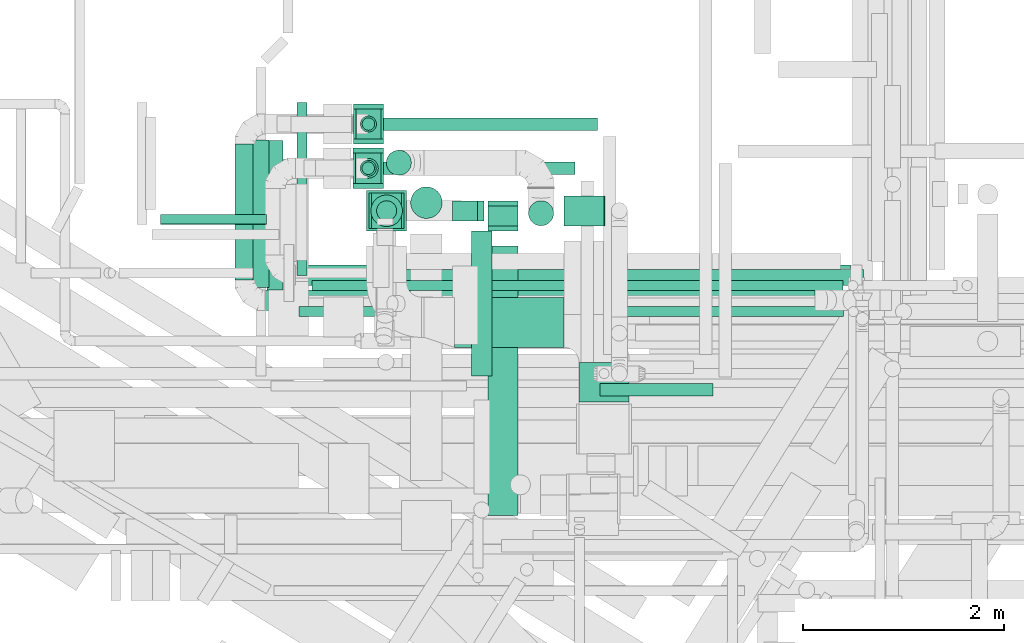
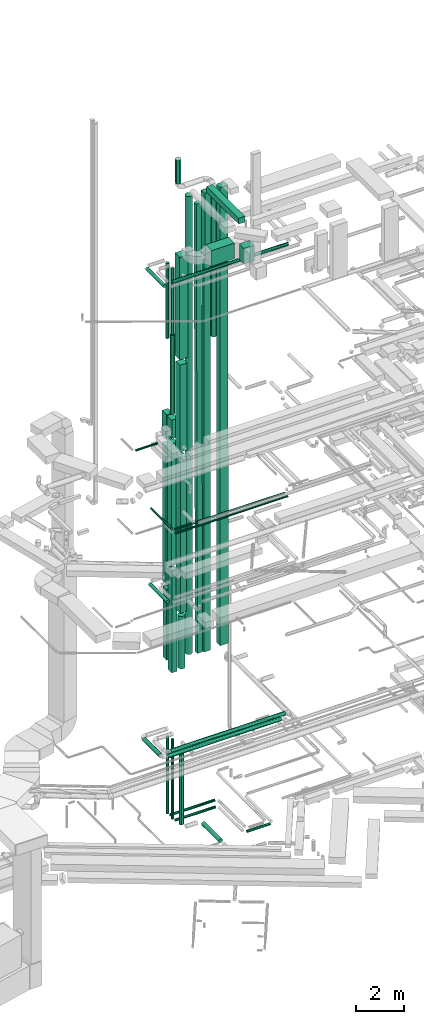
# One storey, part 26 of 337: 40 flow segments.
"""IFC2X3 building model written with IfcOpenShell, lengths in millimetres."""

import ifcopenshell
import ifcopenshell.guid

model = None  # the IFC model being written
_history = None  # IfcOwnerHistory: only IFC2X3 demands one
_inside = {}  # id of a spatial element -> (the spatial element, [elements in it])
_under = {}  # id of a project, library or spatial element -> (it, [spatial elements below it])
_declared = {}  # id of a project -> (the project, [libraries it declares])
_typed = {}  # id of a type object -> (the type object, [elements of that type])
_made_of = {}  # id of a material, layer set ... -> (it, [elements and type objects made of it])


def new_model(schema):
    """Start an empty IFC model of exactly this schema.

    Asked for "IFC4X3", IfcOpenShell would pick the latest addendum, in which some entities
    have other attributes; the version numbers below select the first issue.
    IFC2X3 requires an IfcOwnerHistory on every rooted entity: one is made here for all.
    """
    global model, _history
    if schema == "IFC4X3":
        model = ifcopenshell.file(schema_version=(4, 3, 0, 0))
    else:
        model = ifcopenshell.file(schema=schema)
    _inside.clear()
    _under.clear()
    _declared.clear()
    _typed.clear()
    _made_of.clear()
    _history = None
    if model.schema == "IFC2X3":
        org = make("IfcOrganization", Name="unknown")
        user = make(
            "IfcPersonAndOrganization",
            ThePerson=make("IfcPerson", FamilyName="unknown"),
            TheOrganization=org,
        )
        app = make(
            "IfcApplication",
            ApplicationDeveloper=org,
            Version="unknown",
            ApplicationFullName="unknown",
            ApplicationIdentifier="unknown",
        )
        _history = make(
            "IfcOwnerHistory",
            OwningUser=user,
            OwningApplication=app,
            ChangeAction="ADDED",
            CreationDate=0,
        )
    return model


def make(cls, **values):
    """One entity of the class cls with the attributes given. An attribute that is None is left unset."""
    return model.create_entity(
        cls, **{name: value for name, value in values.items() if value is not None}
    )


def entity(cls, *values):
    """Any entity or typed value of the class cls, its attributes in the order of the schema. None: left unset."""
    e = model.create_entity(cls)
    for i, value in enumerate(values):
        if value is not None:
            e[i] = value
    return e


def rooted(cls, **values):
    """An entity with a GlobalId (a new one), such as an element, a storey or a relation."""
    return make(cls, GlobalId=ifcopenshell.guid.new(), OwnerHistory=_history, **values)


def si_unit(unit_type, name, prefix=None):
    """IfcSIUnit, for example si_unit("LENGTHUNIT", "METRE", prefix="MILLI")."""
    return make("IfcSIUnit", UnitType=unit_type, Prefix=prefix, Name=name)


def converted_unit(unit_type, name, factor, base, dimensions=None, offset=None):
    """IfcConversionBasedUnit, such as the inch: factor (a typed value) times the base unit."""
    return make(
        "IfcConversionBasedUnit"
        if offset is None
        else "IfcConversionBasedUnitWithOffset",
        ConversionOffset=offset,
        Dimensions=None
        if dimensions is None
        else entity("IfcDimensionalExponents", *dimensions),
        UnitType=unit_type,
        Name=name,
        ConversionFactor=make(
            "IfcMeasureWithUnit", ValueComponent=factor, UnitComponent=base
        ),
    )


def derived_unit(unit_type, elements):
    """IfcDerivedUnit: a product of units, each with its exponent."""
    return make(
        "IfcDerivedUnit",
        Elements=[
            make("IfcDerivedUnitElement", Unit=unit, Exponent=power)
            for unit, power in elements
        ],
        UnitType=unit_type,
    )


def assignment(units):
    """IfcUnitAssignment: the units of a project."""
    return None if units is None else make("IfcUnitAssignment", Units=units)


def point(xyz):
    """IfcCartesianPoint."""
    return None if xyz is None else make("IfcCartesianPoint", Coordinates=xyz)


def direction(xyz):
    """IfcDirection."""
    return None if xyz is None else make("IfcDirection", DirectionRatios=xyz)


def frame(location, z_axis=None, x_axis=None):
    """IfcAxis2Placement3D, a coordinate frame: its origin and axes. An axis left out is left unset."""
    return make(
        "IfcAxis2Placement3D",
        Location=point(location),
        Axis=direction(z_axis),
        RefDirection=direction(x_axis),
    )


def frame_2d(location, x_axis=None):
    """IfcAxis2Placement2D, a coordinate frame in the plane: its origin and x axis."""
    return make(
        "IfcAxis2Placement2D", Location=point(location), RefDirection=direction(x_axis)
    )


def origin():
    """The frame at (0, 0, 0) with its axes left unset."""
    return frame((0.0, 0.0, 0.0))


def origin_2d_with_axis():
    """The frame at (0, 0) in the plane with the x axis (1, 0) written out."""
    return frame_2d((0.0, 0.0), x_axis=(1.0, 0.0))


def place(relative_to, where):
    """IfcLocalPlacement: puts the frame where relative to a parent placement (None: the world)."""
    return make(
        "IfcLocalPlacement", PlacementRelTo=relative_to, RelativePlacement=where
    )


def context(
    kind, dimensions, precision=None, world=None, true_north=None, identifier=None
):
    """IfcGeometricRepresentationContext, for example the 3D "Model" context."""
    return make(
        "IfcGeometricRepresentationContext",
        ContextIdentifier=identifier,
        ContextType=kind,
        CoordinateSpaceDimension=dimensions,
        Precision=precision,
        WorldCoordinateSystem=world,
        TrueNorth=true_north,
    )


def subcontext(parent, identifier, kind, view, scale=None):
    """IfcGeometricRepresentationSubContext, for example "Body" below "Model"."""
    return make(
        "IfcGeometricRepresentationSubContext",
        ContextIdentifier=identifier,
        ContextType=kind,
        ParentContext=parent,
        TargetScale=scale,
        TargetView=view,
    )


def project(units=None, contexts=None):
    """IfcProject with its units and contexts."""
    return rooted(
        "IfcProject",
        Name="project",
        RepresentationContexts=contexts,
        UnitsInContext=assignment(units),
    )


def spatial(cls, under=None, at=None, **own):
    """A site, building, storey or space (cls), placed at a placement, below another one or the project."""
    s = rooted(cls, ObjectPlacement=at, **own)
    if under is not None:
        _under.setdefault(under.id(), (under, []))[1].append(s)
    return s


def profile(cls, at=None, kind="AREA", **sizes):
    """A parametric profile (cls). Its sizes go by their IFC names, for example OverallWidth=200.0."""
    return make(cls, ProfileType=kind, Position=at, **sizes)


def rectangle(**sizes):
    """IfcRectangleProfileDef."""
    return profile("IfcRectangleProfileDef", **sizes)


def circle(**sizes):
    """IfcCircleProfileDef."""
    return profile("IfcCircleProfileDef", **sizes)


def extrude(swept, where, along, depth):
    """IfcExtrudedAreaSolid: the profile swept, set in the frame where, extruded along a direction by depth."""
    return make(
        "IfcExtrudedAreaSolid",
        SweptArea=swept,
        Position=where,
        ExtrudedDirection=direction(along),
        Depth=depth,
    )


def shape(context_of_items, identifier, shape_type, items):
    """IfcShapeRepresentation: the items that make up one representation, for example the "Body"."""
    return make(
        "IfcShapeRepresentation",
        ContextOfItems=context_of_items,
        RepresentationIdentifier=identifier,
        RepresentationType=shape_type,
        Items=items,
    )


def made_of(thing, what):
    """Note that an element or type object is made of a material, layer set ...; save() writes the relation."""
    if what is not None:
        _made_of.setdefault(what.id(), (what, []))[1].append(thing)
    return thing


def type_object(cls, material=None, **own):
    """A type object (cls), such as IfcWallType, which elements share."""
    return made_of(rooted(cls, **own), material)


def element(
    cls,
    number,
    at=None,
    inside=None,
    cuts=None,
    type_object=None,
    material=None,
    context=None,
    identifier="Body",
    shape_type=None,
    held_by="IfcProductDefinitionShape",
    body=None,
    shapes=None,
    **own,
):
    """One element of the class cls, such as IfcWall. Its Tag is "e" and its number.

    at: its placement. inside: the storey or other place that contains it. cuts: it is an
    opening in that element (IfcRelVoidsElement). A single representation is given by context,
    identifier, shape_type and body (its items); several are given by shapes. held_by: the class
    of the entity that holds the representations. save() writes the other relations.
    """
    e = rooted(cls, Tag="e%d" % number, ObjectPlacement=at, **own)
    if body is not None:
        shapes = [shape(context, identifier, shape_type, body)]
    if shapes is not None:
        e.Representation = make(held_by, Representations=shapes)
    if inside is not None:
        _inside.setdefault(inside.id(), (inside, []))[1].append(e)
    if cuts is not None:
        rooted(
            "IfcRelVoidsElement", RelatingBuildingElement=cuts, RelatedOpeningElement=e
        )
    if type_object is not None:
        _typed.setdefault(type_object.id(), (type_object, []))[1].append(e)
    return made_of(e, material)


def aggregate(whole, parts):
    """IfcRelAggregates: a whole, such as a stair, and the parts it consists of."""
    return rooted("IfcRelAggregates", RelatingObject=whole, RelatedObjects=parts)


def save(model, path):
    """Write the relations noted so far, then the file.

    IfcRelAggregates (storeys below a building ...), IfcRelContainedInSpatialStructure (elements
    in a storey), IfcRelDefinesByType, IfcRelAssociatesMaterial and IfcRelDeclares: one each for
    every whole, place, type object, material and project.
    """
    for whole, parts in _under.values():
        aggregate(whole, parts)
    for where, things in _inside.values():
        rooted(
            "IfcRelContainedInSpatialStructure",
            RelatedElements=things,
            RelatingStructure=where,
        )
    for kind, things in _typed.values():
        rooted("IfcRelDefinesByType", RelatedObjects=things, RelatingType=kind)
    for what, things in _made_of.values():
        rooted("IfcRelAssociatesMaterial", RelatedObjects=things, RelatingMaterial=what)
    for by, libraries in _declared.values():
        rooted("IfcRelDeclares", RelatingContext=by, RelatedDefinitions=libraries)
    model.write(path)


model = new_model("IFC2X3")

# Units and contexts
model_context = context("Model", 3, precision=0.01, world=origin(), true_north=direction((6.12303176911189e-17, 1.0)))
body_context = subcontext(model_context, "Body", "Model", "MODEL_VIEW")
ifc_project = project(units=[si_unit("LENGTHUNIT", "METRE", prefix="MILLI"), si_unit("AREAUNIT", "SQUARE_METRE"), si_unit("VOLUMEUNIT", "CUBIC_METRE"), converted_unit("PLANEANGLEUNIT", "DEGREE", entity("IfcRatioMeasure", 0.0174532925199433), si_unit("PLANEANGLEUNIT", "RADIAN"), dimensions=[0, 0, 0, 0, 0, 0, 0]), si_unit("MASSUNIT", "GRAM", prefix="KILO"), derived_unit("MASSDENSITYUNIT", [(si_unit("MASSUNIT", "GRAM", prefix="KILO"), 1), (si_unit("LENGTHUNIT", "METRE"), -3)]), derived_unit("MOMENTOFINERTIAUNIT", [(si_unit("LENGTHUNIT", "METRE"), 4)]), si_unit("TIMEUNIT", "SECOND"), si_unit("FREQUENCYUNIT", "HERTZ"), si_unit("THERMODYNAMICTEMPERATUREUNIT", "DEGREE_CELSIUS"), derived_unit("THERMALTRANSMITTANCEUNIT", [(si_unit("MASSUNIT", "GRAM", prefix="KILO"), 1), (si_unit("THERMODYNAMICTEMPERATUREUNIT", "KELVIN"), -1), (si_unit("TIMEUNIT", "SECOND"), -3)]), derived_unit("VOLUMETRICFLOWRATEUNIT", [(si_unit("LENGTHUNIT", "METRE"), 3), (si_unit("TIMEUNIT", "SECOND"), -1)]), derived_unit("MASSFLOWRATEUNIT", [(si_unit("MASSUNIT", "GRAM", prefix="KILO"), 1), (si_unit("TIMEUNIT", "SECOND"), -1)]), derived_unit("ROTATIONALFREQUENCYUNIT", [(si_unit("TIMEUNIT", "SECOND"), -1)]), si_unit("ELECTRICCURRENTUNIT", "AMPERE"), si_unit("ELECTRICVOLTAGEUNIT", "VOLT"), si_unit("POWERUNIT", "WATT"), si_unit("FORCEUNIT", "NEWTON", prefix="KILO"), si_unit("ILLUMINANCEUNIT", "LUX"), si_unit("LUMINOUSFLUXUNIT", "LUMEN"), si_unit("LUMINOUSINTENSITYUNIT", "CANDELA"), derived_unit("USERDEFINED", [(si_unit("MASSUNIT", "GRAM", prefix="KILO"), -1), (si_unit("LENGTHUNIT", "METRE"), -2), (si_unit("TIMEUNIT", "SECOND"), 3), (si_unit("LUMINOUSFLUXUNIT", "LUMEN"), 1)]), derived_unit("LINEARVELOCITYUNIT", [(si_unit("LENGTHUNIT", "METRE"), 1), (si_unit("TIMEUNIT", "SECOND"), -1)]), si_unit("PRESSUREUNIT", "PASCAL"), derived_unit("USERDEFINED", [(si_unit("LENGTHUNIT", "METRE"), -2), (si_unit("MASSUNIT", "GRAM", prefix="KILO"), 1), (si_unit("TIMEUNIT", "SECOND"), -2)]), derived_unit("LINEARFORCEUNIT", [(si_unit("MASSUNIT", "GRAM", prefix="KILO"), 1), (si_unit("LENGTHUNIT", "METRE"), 1), (si_unit("TIMEUNIT", "SECOND"), -2), (si_unit("LENGTHUNIT", "METRE"), -1)]), derived_unit("PLANARFORCEUNIT", [(si_unit("MASSUNIT", "GRAM", prefix="KILO"), 1), (si_unit("LENGTHUNIT", "METRE"), 1), (si_unit("TIMEUNIT", "SECOND"), -2), (si_unit("LENGTHUNIT", "METRE"), -2)])], contexts=[model_context])

# Site, building, storey
site_placement = place(None, origin())
site = spatial("IfcSite", under=ifc_project, at=site_placement, CompositionType="ELEMENT")
building_placement = place(site_placement, origin())
building = spatial("IfcBuilding", under=site, at=building_placement, CompositionType="ELEMENT")
storey_placement = place(building_placement, origin())
storey = spatial("IfcBuildingStorey", under=building, at=storey_placement, CompositionType="ELEMENT", Elevation=0.0)

# Flow segments
duct_segment_type_1 = type_object("IfcDuctSegmentType", PredefinedType="NOTDEFINED")
flow_segment_1_placement = place(storey_placement, frame((7873.56, 14650.47, 11170.0)))
element("IfcFlowSegment", 1, at=flow_segment_1_placement, inside=storey, type_object=duct_segment_type_1, context=body_context, shape_type="SweptSolid", body=[
    extrude(rectangle(XDim=300.000000000001, YDim=300.0, at=origin_2d_with_axis()), frame((150.0, 150.0, 0.0), z_axis=(0.0, 0.0, 1.0), x_axis=(0.0, 1.0, 0.0)), (0.0, 0.0, 1.0), 7060.00000000029),
])
flow_segment_2_placement = place(storey_placement, frame((7898.54, 14650.47, 7270.0)))
element("IfcFlowSegment", 2, at=flow_segment_2_placement, inside=storey, type_object=duct_segment_type_1, context=body_context, shape_type="SweptSolid", body=[
    extrude(rectangle(XDim=300.000000000001, YDim=250.0, at=origin_2d_with_axis()), frame((125.0, 150.0, 0.0), z_axis=(6.6121419226647e-06, 0.0, 1.0), x_axis=(0.0, 1.0, 0.0)), (0.0, 0.0, 1.0), 3600.00000007859),
])
flow_segment_3_placement = place(storey_placement, frame((7873.56, 14600.47, 18530.0)))
element("IfcFlowSegment", 3, at=flow_segment_3_placement, inside=storey, type_object=duct_segment_type_1, context=body_context, shape_type="SweptSolid", body=[
    extrude(rectangle(XDim=300.0, YDim=400.0, at=origin_2d_with_axis()), frame((150.0, 200.0, 0.0), z_axis=(0.0, 0.0, 1.0), x_axis=(-1.0, 0.0, 0.0)), (0.0, 0.0, 1.0), 1300.0),
])
flow_segment_4_placement = place(storey_placement, frame((7871.67, 14159.27, 18885.84)))
element("IfcFlowSegment", 4, at=flow_segment_4_placement, inside=storey, type_object=duct_segment_type_1, context=body_context, shape_type="SweptSolid", body=[
    extrude(rectangle(XDim=400.0, YDim=300.0, at=origin_2d_with_axis()), frame((150.0, 200.0, 0.0), z_axis=(0.0, 1.83537124894428e-05, 1.0), x_axis=(0.0, 1.0, -1.83537124894428e-05)), (0.0, 0.0, 1.0), 940.000000654461),
])
flow_segment_5_placement = place(storey_placement, frame((7896.67, 14209.63, 6895.0)))
element("IfcFlowSegment", 5, at=flow_segment_5_placement, inside=storey, type_object=duct_segment_type_1, context=body_context, shape_type="SweptSolid", body=[
    extrude(rectangle(XDim=249.999999999998, YDim=300.000000000001, at=origin_2d_with_axis()), frame((125.0, 150.0, 0.0), z_axis=(0.0, 0.0, 1.0), x_axis=(-1.0, 0.0, 0.0)), (0.0, 0.0, 1.0), 5200.00000000011),
])
flow_segment_6_placement = place(storey_placement, frame((7871.67, 14209.29, 12394.99)))
element("IfcFlowSegment", 6, at=flow_segment_6_placement, inside=storey, type_object=duct_segment_type_1, context=body_context, shape_type="SweptSolid", body=[
    extrude(rectangle(XDim=299.999999999998, YDim=300.000000000001, at=origin_2d_with_axis()), frame((150.0, 150.36, 0.01), z_axis=(0.0, -5.75082989964242e-05, 1.0), x_axis=(-1.0, 0.0, 0.0)), (0.0, 0.0, 1.0), 6190.84730727097),
])
flow_segment_7_placement = place(storey_placement, frame((8054.69, 13760.69, 10143.28)))
element("IfcFlowSegment", 7, at=flow_segment_7_placement, inside=storey, type_object=duct_segment_type_1, context=body_context, shape_type="SweptSolid", body=[
    extrude(rectangle(XDim=349.999999999998, YDim=300.0, at=origin_2d_with_axis()), frame((150.0, 175.0, 0.0), z_axis=(0.0, 0.0, 1.0), x_axis=(0.0, 1.0, 0.0)), (0.0, 0.0, 1.0), 7936.7197158948),
])
flow_segment_8_placement = place(storey_placement, frame((8029.69, 13760.69, 18380.0)))
element("IfcFlowSegment", 8, at=flow_segment_8_placement, inside=storey, type_object=duct_segment_type_1, context=body_context, shape_type="SweptSolid", body=[
    extrude(rectangle(XDim=349.999999999998, YDim=350.000000000001, at=origin_2d_with_axis()), frame((175.0, 175.0, 0.0), z_axis=(0.0, 0.0, 1.0), x_axis=(0.0, 1.0, 0.0)), (0.0, 0.0, 1.0), 4440.00000000003),
])
flow_segment_9_placement = place(storey_placement, frame((8004.69, 13735.69, 23120.0)))
element("IfcFlowSegment", 9, at=flow_segment_9_placement, inside=storey, type_object=duct_segment_type_1, context=body_context, shape_type="SweptSolid", body=[
    extrude(rectangle(XDim=399.999999999998, YDim=400.0, at=origin_2d_with_axis()), frame((200.0, 200.0, 0.0), z_axis=(0.0, 0.0, 1.0), x_axis=(0.0, -1.0, 0.0)), (0.0, 0.0, 1.0), 5229.99999999995),
])
flow_segment_10_placement = place(storey_placement, frame((8862.99, 13833.89, 7749.67)))
element("IfcFlowSegment", 10, at=flow_segment_10_placement, inside=storey, type_object=duct_segment_type_1, context=body_context, shape_type="SweptSolid", body=[
    extrude(rectangle(XDim=250.0, YDim=199.999999999998, at=frame_2d((0.0, 0.0), x_axis=(0.0, 1.0))), frame((185.48, 100.0, 0.33), z_axis=(-0.0026353336190688, 0.0, 0.999996527502329), x_axis=(0.0, -1.0, 0.0)), (0.0, 0.0, 1.0), 22950.0814303531),
])
flow_segment_11_placement = place(storey_placement, frame((9214.47, 13784.03, 7750.0)))
element("IfcFlowSegment", 11, at=flow_segment_11_placement, inside=storey, type_object=duct_segment_type_1, context=body_context, shape_type="SweptSolid", body=[
    extrude(rectangle(XDim=199.999999999998, YDim=300.0, at=origin_2d_with_axis()), frame((150.0, 100.0, 0.0), z_axis=(0.0, 0.0, 1.0), x_axis=(0.0, -1.0, 0.0)), (0.0, 0.0, 1.0), 19965.0),
])
flow_segment_12_placement = place(storey_placement, frame((8879.69, 12572.81, 28300.0)))
element("IfcFlowSegment", 12, at=flow_segment_12_placement, inside=storey, type_object=duct_segment_type_1, context=body_context, shape_type="SweptSolid", body=[
    extrude(rectangle(XDim=1093.94863999926, YDim=500.000000000001, at=origin_2d_with_axis()), frame((546.97, 250.0, 0.0)), (0.0, 0.0, 1.0), 800.0),
])
flow_segment_13_placement = place(storey_placement, frame((10123.64, 12031.11, 28300.0)))
element("IfcFlowSegment", 13, at=flow_segment_13_placement, inside=storey, type_object=duct_segment_type_1, context=body_context, shape_type="SweptSolid", body=[
    extrude(rectangle(XDim=391.694619999872, YDim=500.000000000001, at=origin_2d_with_axis()), frame((250.0, 195.85, 0.0), z_axis=(0.0, 0.0, 1.0), x_axis=(0.0, -1.0, 0.0)), (0.0, 0.0, 1.0), 800.0),
])
duct_segment_type_2 = type_object("IfcDuctSegmentType", PredefinedType="NOTDEFINED")
flow_segment_14_placement = place(storey_placement, frame((8148.54, 14736.37, -864.1)))
element("IfcFlowSegment", 14, at=flow_segment_14_placement, inside=storey, type_object=duct_segment_type_2, context=body_context, shape_type="SweptSolid", body=[
    extrude(circle(Radius=62.5, at=origin_2d_with_axis()), frame((0.0, 64.1, 64.1), z_axis=(1.0, 0.0, 0.0), x_axis=(0.0, -1.0, 0.0)), (0.0, 0.0, 1.0), 2157.64435623055),
])
flow_segment_15_placement = place(storey_placement, frame((8146.67, 14295.53, -864.1)))
element("IfcFlowSegment", 15, at=flow_segment_15_placement, inside=storey, type_object=duct_segment_type_2, context=body_context, shape_type="SweptSolid", body=[
    extrude(circle(Radius=62.5, at=origin_2d_with_axis()), frame((0.0, 64.1, 64.1), z_axis=(1.0, 0.0, 0.0), x_axis=(0.0, -1.0, 0.0)), (0.0, 0.0, 1.0), 1934.45335999986),
])
flow_segment_16_placement = place(storey_placement, frame((10331.12, 12086.5, -864.1)))
element("IfcFlowSegment", 16, at=flow_segment_16_placement, inside=storey, type_object=duct_segment_type_2, context=body_context, shape_type="SweptSolid", body=[
    extrude(circle(Radius=62.5, at=origin_2d_with_axis()), frame((0.0, 64.1, 64.1), z_axis=(1.0, 0.0, 0.0), x_axis=(0.0, -1.0, 0.0)), (0.0, 0.0, 1.0), 1126.96798000001),
])
flow_segment_17_placement = place(storey_placement, frame((7957.57, 14295.53, -675.0)))
element("IfcFlowSegment", 17, at=flow_segment_17_placement, inside=storey, type_object=duct_segment_type_2, context=body_context, shape_type="SweptSolid", body=[
    extrude(circle(Radius=62.5, at=origin_2d_with_axis()), frame((64.1, 64.1, 0.0), z_axis=(0.0, 0.0, 1.0), x_axis=(0.0, -1.0, 0.0)), (0.0, 0.0, 1.0), 4070.0),
])
flow_segment_18_placement = place(storey_placement, frame((9051.65, 12290.19, -1051.6)))
element("IfcFlowSegment", 18, at=flow_segment_18_placement, inside=storey, type_object=duct_segment_type_2, context=body_context, shape_type="SweptSolid", body=[
    extrude(circle(Radius=100.0, at=origin_2d_with_axis()), frame((101.6, 0.0, 101.6), z_axis=(0.0, 1.0, 0.0), x_axis=(-1.0, 0.0, 0.0)), (0.0, 0.0, 1.0), 1445.50052353826),
])
flow_segment_19_placement = place(storey_placement, frame((8103.1, 13834.09, -750.0)))
element("IfcFlowSegment", 19, at=flow_segment_19_placement, inside=storey, type_object=duct_segment_type_2, context=body_context, shape_type="SweptSolid", body=[
    extrude(circle(Radius=100.0, at=origin_2d_with_axis()), frame((101.6, 101.6, 0.0), z_axis=(0.0, 0.0, 1.0), x_axis=(0.0, -1.0, 0.0)), (0.0, 0.0, 1.0), 3803.28028410524),
])
flow_segment_20_placement = place(storey_placement, frame((7011.97, 13146.64, 11368.4)))
element("IfcFlowSegment", 20, at=flow_segment_20_placement, inside=storey, type_object=duct_segment_type_2, context=body_context, shape_type="SweptSolid", body=[
    extrude(circle(Radius=80.0, at=origin_2d_with_axis()), frame((81.6, 0.0, 81.6), z_axis=(0.0, 1.0, 0.0), x_axis=(-1.0, 0.0, 0.0)), (0.0, 0.0, 1.0), 1490.00000000004),
])
flow_segment_21_placement = place(storey_placement, frame((7294.17, 13191.78, 3558.4)))
element("IfcFlowSegment", 21, at=flow_segment_21_placement, inside=storey, type_object=duct_segment_type_2, context=body_context, shape_type="SweptSolid", body=[
    extrude(circle(Radius=100.0, at=origin_2d_with_axis()), frame((0.0, 101.6, 101.6), z_axis=(1.0, 0.0, 0.0), x_axis=(0.0, -1.0, 0.0)), (0.0, 0.0, 1.0), 5535.00000000002),
])
flow_segment_22_placement = place(storey_placement, frame((6692.54, 13243.34, 3558.4)))
element("IfcFlowSegment", 22, at=flow_segment_22_placement, inside=storey, type_object=duct_segment_type_2, context=body_context, shape_type="SweptSolid", body=[
    extrude(circle(Radius=100.0, at=origin_2d_with_axis()), frame((101.6, 0.0, 101.6), z_axis=(0.0, 1.0, 0.0), x_axis=(-1.0, 0.0, 0.0)), (0.0, 0.0, 1.0), 1357.05222313368),
])
flow_segment_23_placement = place(storey_placement, frame((6994.13, 12941.75, 3558.4)))
element("IfcFlowSegment", 23, at=flow_segment_23_placement, inside=storey, type_object=duct_segment_type_2, context=body_context, shape_type="SweptSolid", body=[
    extrude(circle(Radius=100.0, at=origin_2d_with_axis()), frame((0.0, 101.6, 101.6), z_axis=(1.0, 0.0, 0.0), x_axis=(0.0, -1.0, 0.0)), (0.0, 0.0, 1.0), 5484.65728752541),
])
flow_segment_24_placement = place(storey_placement, frame((8045.6, 13776.59, 7264.28)))
element("IfcFlowSegment", 24, at=flow_segment_24_placement, inside=storey, type_object=duct_segment_type_2, context=body_context, shape_type="SweptSolid", body=[
    extrude(circle(Radius=157.5, at=origin_2d_with_axis()), frame((159.1, 159.1, 0.0), z_axis=(0.0, 0.0, 1.0), x_axis=(0.0, 1.0, 0.0)), (0.0, 0.0, 1.0), 2678.99999999999),
])
flow_segment_25_placement = place(storey_placement, frame((7307.08, 13290.0, 14948.4)))
element("IfcFlowSegment", 25, at=flow_segment_25_placement, inside=storey, type_object=duct_segment_type_2, context=body_context, shape_type="SweptSolid", body=[
    extrude(circle(Radius=50.0, at=origin_2d_with_axis()), frame((51.6, 0.0, 51.6), z_axis=(0.0, 1.0, 0.0), x_axis=(-1.0, 0.0, 0.0)), (0.0, 0.0, 1.0), 1724.42293512657),
])
flow_segment_26_placement = place(storey_placement, frame((7458.67, 13138.4, 14948.4)))
element("IfcFlowSegment", 26, at=flow_segment_26_placement, inside=storey, type_object=duct_segment_type_2, context=body_context, shape_type="SweptSolid", body=[
    extrude(circle(Radius=50.0, at=origin_2d_with_axis()), frame((0.0, 51.6, 51.6), z_axis=(1.0, 0.0, 0.0), x_axis=(0.0, -1.0, 0.0)), (0.0, 0.0, 1.0), 5295.00000000002),
])
flow_segment_27_placement = place(storey_placement, frame((7329.32, 12878.4, 14948.4)))
element("IfcFlowSegment", 27, at=flow_segment_27_placement, inside=storey, type_object=duct_segment_type_2, context=body_context, shape_type="SweptSolid", body=[
    extrude(circle(Radius=50.0, at=origin_2d_with_axis()), frame((0.0, 51.6, 51.6), z_axis=(1.0, 0.0, 0.0), x_axis=(0.0, 1.0, 0.0)), (0.0, 0.0, 1.0), 5429.0),
])
flow_segment_28_placement = place(storey_placement, frame((7959.44, 14736.37, -675.0)))
element("IfcFlowSegment", 28, at=flow_segment_28_placement, inside=storey, type_object=duct_segment_type_2, context=body_context, shape_type="SweptSolid", body=[
    extrude(circle(Radius=62.5, at=origin_2d_with_axis()), frame((64.1, 64.1, 0.0), z_axis=(0.0, 0.0, 1.0), x_axis=(0.0, 1.0, 0.0)), (0.0, 0.0, 1.0), 3969.99999999988),
])
flow_segment_29_placement = place(storey_placement, frame((5950.44, 13798.75, 19098.4)))
element("IfcFlowSegment", 29, at=flow_segment_29_placement, inside=storey, type_object=duct_segment_type_2, context=body_context, shape_type="SweptSolid", body=[
    extrude(circle(Radius=50.0, at=origin_2d_with_axis()), frame((0.0, 51.6, 51.6), z_axis=(1.0, 0.0, 0.0), x_axis=(0.0, 1.0, 0.0)), (0.0, 0.0, 1.0), 1054.41083713572),
])
flow_segment_30_placement = place(storey_placement, frame((7941.97, 14718.87, 23600.0)))
element("IfcFlowSegment", 30, at=flow_segment_30_placement, inside=storey, type_object=duct_segment_type_2, context=body_context, shape_type="SweptSolid", body=[
    extrude(circle(Radius=80.0, at=origin_2d_with_axis()), frame((81.6, 81.6, 0.0), z_axis=(0.0, 0.0, 1.0), x_axis=(-1.0, 0.0, 0.0)), (0.0, 0.0, 1.0), 3839.99999999993),
])
flow_segment_31_placement = place(storey_placement, frame((9617.87, 13784.09, 23660.03)))
element("IfcFlowSegment", 31, at=flow_segment_31_placement, inside=storey, type_object=duct_segment_type_2, context=body_context, shape_type="SweptSolid", body=[
    extrude(circle(Radius=125.0, at=origin_2d_with_axis()), frame((126.87, 126.6, 0.0)), (0.0, 0.0, 1.0), 7490.26167212249),
])
flow_segment_32_placement = place(storey_placement, frame((6870.59, 13169.26, 27518.4)))
element("IfcFlowSegment", 32, at=flow_segment_32_placement, inside=storey, type_object=duct_segment_type_2, context=body_context, shape_type="SweptSolid", body=[
    extrude(circle(Radius=80.0, at=origin_2d_with_axis()), frame((81.6, 0.0, 81.6), z_axis=(0.0, 1.0, 0.0), x_axis=(-1.0, 0.0, 0.0)), (0.0, 0.0, 1.0), 1471.13335435462),
])
flow_segment_33_placement = place(storey_placement, frame((7920.07, 14257.7, 20025.85)))
element("IfcFlowSegment", 33, at=flow_segment_33_placement, inside=storey, type_object=duct_segment_type_2, context=body_context, shape_type="SweptSolid", body=[
    extrude(circle(Radius=100.0, at=origin_2d_with_axis()), frame((101.6, 101.6, 0.0), z_axis=(0.0, 0.0, 1.0), x_axis=(0.0, 1.0, 0.0)), (0.0, 0.0, 1.0), 4020.0),
])
flow_segment_34_placement = place(storey_placement, frame((7940.07, 14277.7, 24085.85)))
element("IfcFlowSegment", 34, at=flow_segment_34_placement, inside=storey, type_object=duct_segment_type_2, context=body_context, shape_type="SweptSolid", body=[
    extrude(circle(Radius=80.0, at=origin_2d_with_axis()), frame((81.6, 81.6, 0.0)), (0.0, 0.0, 1.0), 3354.15270296617),
])
flow_segment_35_placement = place(storey_placement, frame((7379.44, 13188.36, 27518.4)))
element("IfcFlowSegment", 35, at=flow_segment_35_placement, inside=storey, type_object=duct_segment_type_2, context=body_context, shape_type="SweptSolid", body=[
    extrude(circle(Radius=80.0, at=origin_2d_with_axis()), frame((0.0, 81.6, 81.6), z_axis=(1.0, 0.0, 0.0), x_axis=(0.0, -1.0, 0.0)), (0.0, 0.0, 1.0), 5580.00000000002),
])
flow_segment_36_placement = place(storey_placement, frame((8199.8, 14288.02, 31650.28)))
element("IfcFlowSegment", 36, at=flow_segment_36_placement, inside=storey, type_object=duct_segment_type_2, context=body_context, shape_type="SweptSolid", body=[
    extrude(circle(Radius=125.0, at=origin_2d_with_axis()), frame((126.6, 126.72, 0.01), z_axis=(0.0, -0.000101428777969619, 0.999999994856102), x_axis=(-1.0, 0.0, 0.0)), (0.0, 0.0, 1.0), 1210.00000622676),
])
flow_segment_37_placement = place(storey_placement, frame((8442.31, 13857.62, 7807.5)))
element("IfcFlowSegment", 37, at=flow_segment_37_placement, inside=storey, type_object=duct_segment_type_2, context=body_context, shape_type="SweptSolid", body=[
    extrude(circle(Radius=157.5, at=origin_2d_with_axis()), frame((159.1, 159.1, 0.0)), (0.0, 0.0, 1.0), 23377.5),
])
duct_segment_type_3 = type_object("IfcDuctSegmentType", PredefinedType="NOTDEFINED")
flow_segment_38_placement = place(storey_placement, frame((9214.47, 10896.44, 31350.0)))
element("IfcFlowSegment", 38, at=flow_segment_38_placement, inside=storey, type_object=duct_segment_type_3, context=body_context, shape_type="SweptSolid", body=[
    extrude(rectangle(XDim=2687.58936500018, YDim=300.0, at=origin_2d_with_axis()), frame((150.0, 1343.79, 0.0), z_axis=(0.0, 0.0, 1.0), x_axis=(0.0, 1.0, 0.0)), (0.0, 0.0, 1.0), 300.000000000001),
])
flow_segment_39_placement = place(storey_placement, frame((9214.47, 13734.03, 28015.0)))
element("IfcFlowSegment", 39, at=flow_segment_39_placement, inside=storey, type_object=duct_segment_type_3, context=body_context, shape_type="SweptSolid", body=[
    extrude(rectangle(XDim=299.999999999999, YDim=299.999999999999, at=origin_2d_with_axis()), frame((150.0, 150.0, 0.0), z_axis=(0.0, 0.0, 1.0), x_axis=(-1.0, 0.0, 0.0)), (0.0, 0.0, 1.0), 3185.00000000004),
])
flow_segment_40_placement = place(storey_placement, frame((9974.03, 13784.02, 7799.95)))
element("IfcFlowSegment", 40, at=flow_segment_40_placement, inside=storey, type_object=duct_segment_type_3, context=body_context, shape_type="SweptSolid", body=[
    extrude(rectangle(XDim=400.000000000002, YDim=299.999999999999, at=origin_2d_with_axis()), frame((205.98, 150.0, 0.05), z_axis=(-0.000255662932642351, 0.0, 0.999999967318232), x_axis=(-0.999999967318232, 0.0, -0.000255662932642351)), (0.0, 0.0, 1.0), 23400.0007614852),
])

save(model, "model.ifc")
